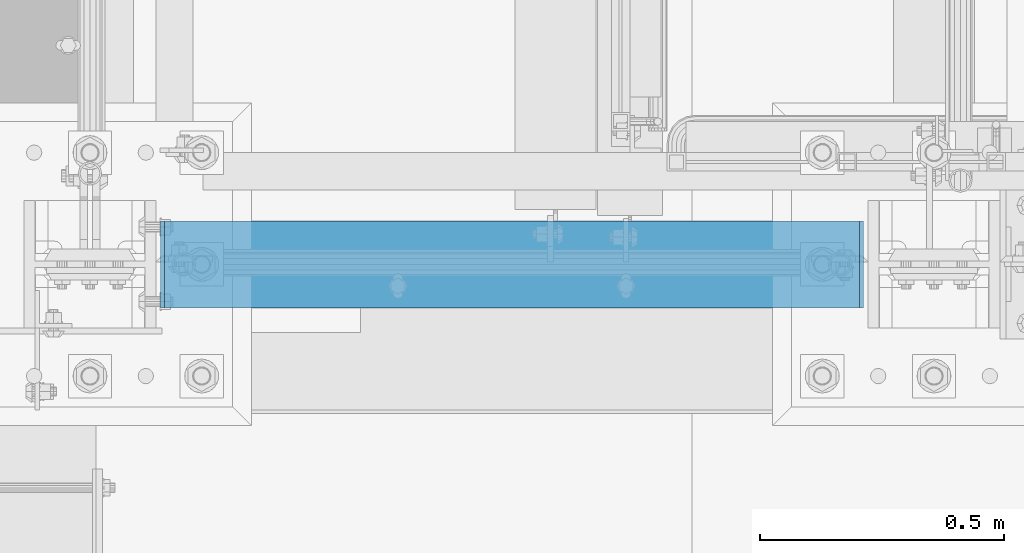
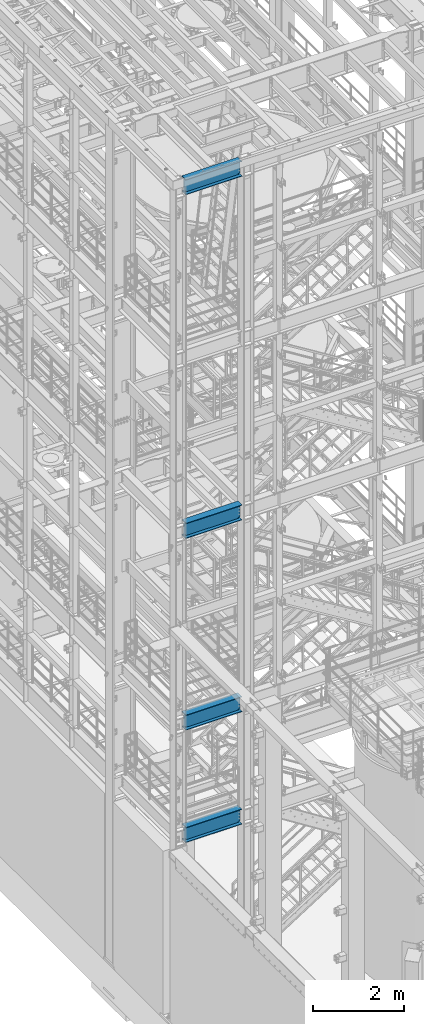
# One storey, part 932 of 1876: 4 beams, 4 elements without a shape of their own.
"""IFC2X3 building model written with IfcOpenShell, lengths in millimetres."""

import ifcopenshell
import ifcopenshell.guid

model = None  # the IFC model being written
_history = None  # IfcOwnerHistory: only IFC2X3 demands one
_inside = {}  # id of a spatial element -> (the spatial element, [elements in it])
_under = {}  # id of a project, library or spatial element -> (it, [spatial elements below it])
_declared = {}  # id of a project -> (the project, [libraries it declares])
_typed = {}  # id of a type object -> (the type object, [elements of that type])
_made_of = {}  # id of a material, layer set ... -> (it, [elements and type objects made of it])


def new_model(schema):
    """Start an empty IFC model of exactly this schema.

    Asked for "IFC4X3", IfcOpenShell would pick the latest addendum, in which some entities
    have other attributes; the version numbers below select the first issue.
    IFC2X3 requires an IfcOwnerHistory on every rooted entity: one is made here for all.
    """
    global model, _history
    if schema == "IFC4X3":
        model = ifcopenshell.file(schema_version=(4, 3, 0, 0))
    else:
        model = ifcopenshell.file(schema=schema)
    _inside.clear()
    _under.clear()
    _declared.clear()
    _typed.clear()
    _made_of.clear()
    _history = None
    if model.schema == "IFC2X3":
        org = make("IfcOrganization", Name="unknown")
        user = make(
            "IfcPersonAndOrganization",
            ThePerson=make("IfcPerson", FamilyName="unknown"),
            TheOrganization=org,
        )
        app = make(
            "IfcApplication",
            ApplicationDeveloper=org,
            Version="unknown",
            ApplicationFullName="unknown",
            ApplicationIdentifier="unknown",
        )
        _history = make(
            "IfcOwnerHistory",
            OwningUser=user,
            OwningApplication=app,
            ChangeAction="ADDED",
            CreationDate=0,
        )
    return model


def make(cls, **values):
    """One entity of the class cls with the attributes given. An attribute that is None is left unset."""
    return model.create_entity(
        cls, **{name: value for name, value in values.items() if value is not None}
    )


def rooted(cls, **values):
    """An entity with a GlobalId (a new one), such as an element, a storey or a relation."""
    return make(cls, GlobalId=ifcopenshell.guid.new(), OwnerHistory=_history, **values)


def si_unit(unit_type, name, prefix=None):
    """IfcSIUnit, for example si_unit("LENGTHUNIT", "METRE", prefix="MILLI")."""
    return make("IfcSIUnit", UnitType=unit_type, Prefix=prefix, Name=name)


def assignment(units):
    """IfcUnitAssignment: the units of a project."""
    return None if units is None else make("IfcUnitAssignment", Units=units)


def point(xyz):
    """IfcCartesianPoint."""
    return None if xyz is None else make("IfcCartesianPoint", Coordinates=xyz)


def direction(xyz):
    """IfcDirection."""
    return None if xyz is None else make("IfcDirection", DirectionRatios=xyz)


def frame(location, z_axis=None, x_axis=None):
    """IfcAxis2Placement3D, a coordinate frame: its origin and axes. An axis left out is left unset."""
    return make(
        "IfcAxis2Placement3D",
        Location=point(location),
        Axis=direction(z_axis),
        RefDirection=direction(x_axis),
    )


def origin_with_axes():
    """The frame at (0, 0, 0) with the z axis (0, 0, 1) and the x axis (1, 0, 0) written out."""
    return frame((0.0, 0.0, 0.0), z_axis=(0.0, 0.0, 1.0), x_axis=(1.0, 0.0, 0.0))


def place(relative_to, where):
    """IfcLocalPlacement: puts the frame where relative to a parent placement (None: the world)."""
    return make(
        "IfcLocalPlacement", PlacementRelTo=relative_to, RelativePlacement=where
    )


def context(
    kind, dimensions, precision=None, world=None, true_north=None, identifier=None
):
    """IfcGeometricRepresentationContext, for example the 3D "Model" context."""
    return make(
        "IfcGeometricRepresentationContext",
        ContextIdentifier=identifier,
        ContextType=kind,
        CoordinateSpaceDimension=dimensions,
        Precision=precision,
        WorldCoordinateSystem=world,
        TrueNorth=true_north,
    )


def subcontext(parent, identifier, kind, view, scale=None):
    """IfcGeometricRepresentationSubContext, for example "Body" below "Model"."""
    return make(
        "IfcGeometricRepresentationSubContext",
        ContextIdentifier=identifier,
        ContextType=kind,
        ParentContext=parent,
        TargetScale=scale,
        TargetView=view,
    )


def project(units=None, contexts=None):
    """IfcProject with its units and contexts."""
    return rooted(
        "IfcProject",
        Name="project",
        RepresentationContexts=contexts,
        UnitsInContext=assignment(units),
    )


def spatial(cls, under=None, at=None, **own):
    """A site, building, storey or space (cls), placed at a placement, below another one or the project."""
    s = rooted(cls, ObjectPlacement=at, **own)
    if under is not None:
        _under.setdefault(under.id(), (under, []))[1].append(s)
    return s


def faces_of(points, faces, orient=None, outer=None):
    """IfcFace entities. A face is a list of loops; a loop is a list of indices into points, from 0.

    orient and outer hold one flag for each loop. By default every Orientation is true, the
    first loop of a face is its IfcFaceOuterBound and the others are IfcFaceBound.
    """
    made = []
    for i, loops in enumerate(faces):
        bounds = []
        for j, loop in enumerate(loops):
            is_outer = j == 0 if outer is None else outer[i][j]
            bounds.append(
                make(
                    "IfcFaceOuterBound" if is_outer else "IfcFaceBound",
                    Bound=make("IfcPolyLoop", Polygon=[points[k] for k in loop]),
                    Orientation=True if orient is None else orient[i][j],
                )
            )
        made.append(make("IfcFace", Bounds=bounds))
    return made


def faceted_brep(points, faces, orient=None, outer=None, voids=None):
    """IfcFacetedBrep: a solid bounded by flat faces; with voids (closed shells), ...WithVoids."""
    shared = [point(p) for p in points]
    hull = make("IfcClosedShell", CfsFaces=faces_of(shared, faces, orient, outer))
    if voids is None:
        return make("IfcFacetedBrep", Outer=hull)
    return make(
        "IfcFacetedBrepWithVoids",
        Outer=hull,
        Voids=[
            make(cls, CfsFaces=faces_of(shared, fs, o, b)) for cls, fs, o, b in voids
        ],
    )


def shape(context_of_items, identifier, shape_type, items):
    """IfcShapeRepresentation: the items that make up one representation, for example the "Body"."""
    return make(
        "IfcShapeRepresentation",
        ContextOfItems=context_of_items,
        RepresentationIdentifier=identifier,
        RepresentationType=shape_type,
        Items=items,
    )


def material(Name=None, Category=None):
    """IfcMaterial."""
    return make("IfcMaterial", Name=Name, Category=Category)


def made_of(thing, what):
    """Note that an element or type object is made of a material, layer set ...; save() writes the relation."""
    if what is not None:
        _made_of.setdefault(what.id(), (what, []))[1].append(thing)
    return thing


def type_object(cls, material=None, **own):
    """A type object (cls), such as IfcWallType, which elements share."""
    return made_of(rooted(cls, **own), material)


def element(
    cls,
    number,
    at=None,
    inside=None,
    cuts=None,
    type_object=None,
    material=None,
    context=None,
    identifier="Body",
    shape_type=None,
    held_by="IfcProductDefinitionShape",
    body=None,
    shapes=None,
    **own,
):
    """One element of the class cls, such as IfcWall. Its Tag is "e" and its number.

    at: its placement. inside: the storey or other place that contains it. cuts: it is an
    opening in that element (IfcRelVoidsElement). A single representation is given by context,
    identifier, shape_type and body (its items); several are given by shapes. held_by: the class
    of the entity that holds the representations. save() writes the other relations.
    """
    e = rooted(cls, Tag="e%d" % number, ObjectPlacement=at, **own)
    if body is not None:
        shapes = [shape(context, identifier, shape_type, body)]
    if shapes is not None:
        e.Representation = make(held_by, Representations=shapes)
    if inside is not None:
        _inside.setdefault(inside.id(), (inside, []))[1].append(e)
    if cuts is not None:
        rooted(
            "IfcRelVoidsElement", RelatingBuildingElement=cuts, RelatedOpeningElement=e
        )
    if type_object is not None:
        _typed.setdefault(type_object.id(), (type_object, []))[1].append(e)
    return made_of(e, material)


def aggregate(whole, parts):
    """IfcRelAggregates: a whole, such as a stair, and the parts it consists of."""
    return rooted("IfcRelAggregates", RelatingObject=whole, RelatedObjects=parts)


def save(model, path):
    """Write the relations noted so far, then the file.

    IfcRelAggregates (storeys below a building ...), IfcRelContainedInSpatialStructure (elements
    in a storey), IfcRelDefinesByType, IfcRelAssociatesMaterial and IfcRelDeclares: one each for
    every whole, place, type object, material and project.
    """
    for whole, parts in _under.values():
        aggregate(whole, parts)
    for where, things in _inside.values():
        rooted(
            "IfcRelContainedInSpatialStructure",
            RelatedElements=things,
            RelatingStructure=where,
        )
    for kind, things in _typed.values():
        rooted("IfcRelDefinesByType", RelatedObjects=things, RelatingType=kind)
    for what, things in _made_of.values():
        rooted("IfcRelAssociatesMaterial", RelatedObjects=things, RelatingMaterial=what)
    for by, libraries in _declared.values():
        rooted("IfcRelDeclares", RelatingContext=by, RelatedDefinitions=libraries)
    model.write(path)


model = new_model("IFC2X3")

# Units and contexts
model_context = context("Model", 3, precision=1e-05, world=origin_with_axes())
body_context = subcontext(model_context, "Body", "Model", "MODEL_VIEW")
ifc_project = project(units=[si_unit("LENGTHUNIT", "METRE", prefix="MILLI"), si_unit("AREAUNIT", "SQUARE_METRE"), si_unit("VOLUMEUNIT", "CUBIC_METRE"), si_unit("MASSUNIT", "GRAM", prefix="KILO"), si_unit("TIMEUNIT", "SECOND"), si_unit("PLANEANGLEUNIT", "RADIAN"), si_unit("SOLIDANGLEUNIT", "STERADIAN"), si_unit("THERMODYNAMICTEMPERATUREUNIT", "DEGREE_CELSIUS"), si_unit("LUMINOUSINTENSITYUNIT", "LUMEN")], contexts=[model_context])

# Site, building, storey
site_placement = place(None, origin_with_axes())
site = spatial("IfcSite", under=ifc_project, at=site_placement, CompositionType="ELEMENT")
building_placement = place(site_placement, origin_with_axes())
building = spatial("IfcBuilding", under=site, at=building_placement, Name="Undefined", CompositionType="ELEMENT")
storey_placement = place(building_placement, origin_with_axes())
storey = spatial("IfcBuildingStorey", under=building, at=storey_placement, Name="Undefined", CompositionType="ELEMENT", Elevation=0.0)

# Assembly, beam
assembly_1_placement = place(storey_placement, origin_with_axes())
assembly_1 = element("IfcElementAssembly", 1, at=assembly_1_placement, inside=storey, Name="BEAM", AssemblyPlace="NOTDEFINED", PredefinedType="RIGID_FRAME")
ifc_material = material(Name="STEEL/A992")
beam_type = type_object("IfcBeamType", Name="W16X45", PredefinedType="NOTDEFINED")
beam_1_placement = place(assembly_1_placement, frame((0.0, -7112.0, 13104.8125), z_axis=(0.0, 0.0, 1.0), x_axis=(1.0, 0.0, 0.0)))
beam_1 = element("IfcBeam", 2, at=beam_1_placement, type_object=beam_type, material=ifc_material, Name="BEAM", ObjectType="W16X45", context=body_context, shape_type="Brep", body=[
    faceted_brep([(1582.7375, 4.76249999999982, 161.924999999999), (1573.21249970572, -4.76249999999982, 161.924999999999), (1573.21249970572, -4.76249999999982, -161.924999999999), (1582.7375, 4.76249999999982, -161.924999999999), (144.4625, 88.8999999999996, 190.5), (152.711099599373, 88.8999999999996, 204.787499999999), (1574.48890040062, 88.8999999999996, 204.787499999999), (1582.7375, 88.8999999999996, 190.5), (144.4625, 4.76249999999982, 190.5), (1582.7375, 4.76249999999982, 190.5), (152.711120260645, -88.8999999999996, -190.5), (144.4625, -88.8999999999996, -204.787499999999), (1582.7375, -88.8999999999996, -204.787499999999), (1574.48887973935, -88.8999999999996, -190.5), (144.4625, 88.8999999999996, -204.787499999999), (1582.7375, 88.8999999999996, -204.787499999999), (152.711120260645, 88.8999999999996, -190.5), (1574.48887973935, 88.8999999999996, -190.5), (152.711120260645, 4.76249999999982, -190.5), (1574.48887973935, 4.76249999999982, -190.5), (1530.71330732956, -4.76249999999982, -163.290718362852), (1530.71330732956, 4.76249999999982, -163.290718362852), (1535.62775003691, 4.76249999999982, -161.924999999999), (1535.62775003691, -4.76249999999982, -161.924999999999), (1527.20815489359, -4.76249999999982, -166.996233194965), (1527.20815489359, 4.76249999999982, -166.996233194965), (1526.11744784461, -4.76249999999982, -171.978932453771), (1526.11744784461, 4.76249999999982, -171.978932453771), (1527.75396281358, -4.76249999999982, -176.80995227641), (1527.75396281358, 4.76249999999982, -176.80995227641), (1531.64840454932, -4.76249999999982, -180.103925156887), (1531.64840454932, 4.76249999999982, -180.103925156887), (1553.39349932861, -4.76249999999982, -190.102999496459), (1553.39349932861, 4.76249999999982, -190.102999496459), (1574.25968949887, -4.76249999999982, -190.102999496459), (1574.25968949887, 4.76249999999982, -190.102999496459), (1574.48887973935, -4.76249999999982, -190.5), (152.711120260645, -4.76249999999982, -190.5), (152.940310501126, -4.76249999999982, -190.102999496459), (152.940310501126, 4.76249999999982, -190.102999496459), (173.806500671387, -4.76249999999982, -190.102999496459), (173.806500671387, 4.76249999999982, -190.102999496459), (195.551595450686, -4.76249999999982, -180.103925156884), (195.551595450686, 4.76249999999982, -180.103925156884), (199.446037186428, -4.76249999999982, -176.80995227641), (199.446037186428, 4.76249999999982, -176.80995227641), (201.082552155395, -4.76249999999982, -171.978932453767), (201.082552155395, 4.76249999999982, -171.978932453767), (199.991845106413, -4.76249999999982, -166.996233194965), (199.991845106413, 4.76249999999982, -166.996233194965), (196.486692670442, -4.76249999999982, -163.290718362852), (196.486692670442, 4.76249999999982, -163.290718362852), (191.572249963099, -4.76249999999982, -161.924999999999), (191.572249963099, 4.76249999999982, -161.924999999999), (153.987500294277, -4.76249999999982, -161.924999999996), (144.4625, 4.76249999999982, -161.924999999996), (153.987500294277, -4.7625002942832, 161.925000000003), (144.4625, 4.76249999999982, 161.925000000003), (190.80324988243, -4.76249999999982, 161.924999999999), (190.80324988243, 4.76249999999982, 161.924999999999), (195.717692628333, -4.76249999999982, 163.290718386077), (195.717692628333, 4.76249999999982, 163.290718386077), (199.22284506784, -4.76249999999982, 166.996233274545), (199.22284506784, 4.76249999999982, 166.996233274545), (200.313552067229, -4.76249999999982, 171.978932588601), (200.313552067229, 4.76249999999982, 171.978932588601), (198.677037004441, -4.76249999999982, 176.80995242525), (198.677037004441, 4.76249999999982, 176.80995242525), (194.782595165536, -4.76249999999982, 180.103925250914), (194.782595165536, 4.76249999999982, 180.103925250914), (173.037499237061, -4.76249999999982, 190.102999496463), (173.037499237061, 4.76249999999982, 190.102999496463), (144.4625, -4.76249999999982, 190.102999496463), (144.4625, 4.76249999999982, 190.102999496463), (144.4625, -4.76249999999982, 190.5), (152.711099599373, -88.8999999999996, 204.787499999999), (144.4625, -88.8999999999996, 190.5), (1582.7375, -4.76249999999982, 190.5), (1582.7375, -88.8999999999996, 190.5), (1574.48890040062, -88.8999999999996, 204.787499999999), (1582.7375, -4.76249999999982, 190.102999496459), (1582.7375, 4.76249999999982, 190.102999496459), (1554.16250076294, -4.76249999999982, 190.102999496459), (1554.16250076294, 4.76249999999982, 190.102999496459), (1532.41740483447, -4.76249999999982, 180.103925250914), (1532.41740483447, 4.76249999999982, 180.103925250914), (1528.52296299556, -4.76249999999982, 176.80995242525), (1528.52296299556, 4.76249999999982, 176.80995242525), (1526.88644793277, -4.76249999999982, 171.978932588601), (1526.88644793277, 4.76249999999982, 171.978932588601), (1527.97715493216, -4.76249999999982, 166.996233274542), (1527.97715493216, 4.76249999999982, 166.996233274542), (1531.48230737167, -4.76249999999982, 163.290718386077), (1531.48230737167, 4.76249999999982, 163.290718386077), (1536.39675011757, -4.76249999999982, 161.924999999999), (1536.39675011757, 4.76249999999982, 161.924999999999)], [[[0, 1, 2, 3]], [[4, 5, 6, 7]], [[8, 4, 7, 9]], [[10, 11, 12, 13]], [[11, 14, 15, 12]], [[14, 16, 17, 15]], [[16, 18, 19, 17]], [[20, 21, 22, 23]], [[24, 25, 21, 20]], [[26, 27, 25, 24]], [[28, 29, 27, 26]], [[30, 31, 29, 28]], [[32, 33, 31, 30]], [[33, 32, 34, 35]], [[12, 15, 17, 19, 35, 34, 36, 13]], [[37, 10, 13, 36]], [[38, 39, 18, 16, 14, 11, 10, 37]], [[40, 41, 39, 38]], [[42, 43, 41, 40]], [[44, 45, 43, 42]], [[46, 47, 45, 44]], [[48, 49, 47, 46]], [[50, 51, 49, 48]], [[52, 53, 51, 50]], [[53, 52, 54, 55]], [[56, 57, 55, 54]], [[58, 59, 57, 56]], [[60, 61, 59, 58]], [[62, 63, 61, 60]], [[64, 65, 63, 62]], [[66, 67, 65, 64]], [[68, 69, 67, 66]], [[70, 71, 69, 68]], [[71, 70, 72, 73]], [[73, 72, 74, 8]], [[75, 5, 4, 8, 74, 76]], [[76, 74, 77, 78]], [[75, 76, 78, 79]], [[5, 75, 79, 6]], [[78, 77, 9, 7, 6, 79]], [[80, 81, 9, 77]], [[82, 83, 81, 80]], [[84, 85, 83, 82]], [[86, 87, 85, 84]], [[88, 89, 87, 86]], [[90, 91, 89, 88]], [[92, 93, 91, 90]], [[94, 95, 93, 92]], [[22, 21, 25, 27, 29, 31, 33, 35, 19, 18, 39, 41, 43, 45, 47, 49, 51, 53, 55, 57, 59, 61, 63, 65, 67, 69, 71, 73, 8, 9, 81, 83, 85, 87, 89, 91, 93, 95, 0, 3]], [[23, 22, 3, 2]], [[94, 92, 90, 88, 86, 84, 82, 80, 77, 74, 72, 70, 68, 66, 64, 62, 60, 58, 56, 54, 52, 50, 48, 46, 44, 42, 40, 38, 37, 36, 34, 32, 30, 28, 26, 24, 20, 23, 2, 1]], [[95, 94, 1, 0]]]),
])
aggregate(assembly_1, [beam_1])

assembly_2_placement = place(storey_placement, origin_with_axes())
assembly_2 = element("IfcElementAssembly", 3, at=assembly_2_placement, inside=storey, Name="BEAM", AssemblyPlace="NOTDEFINED", PredefinedType="RIGID_FRAME")
beam_2_placement = place(assembly_2_placement, frame((0.0, -7112.0, 7948.6125), z_axis=(0.0, 0.0, 1.0), x_axis=(1.0, 0.0, 0.0)))
beam_2 = element("IfcBeam", 4, at=beam_2_placement, type_object=beam_type, material=ifc_material, Name="BEAM", ObjectType="W16X45", context=body_context, shape_type="Brep", body=[
    faceted_brep([(1582.7375, 4.76249999999982, 161.924999999999), (1573.21249970572, -4.76249999999982, 161.924999999999), (1573.21249970572, -4.76249999999982, -161.924999999999), (1582.7375, 4.76249999999982, -161.924999999999), (144.4625, 88.8999999999996, 190.5), (152.711099599373, 88.8999999999996, 204.787499999999), (1574.48890040062, 88.8999999999996, 204.787499999999), (1582.7375, 88.8999999999996, 190.5), (144.4625, 4.76249999999982, 190.5), (1582.7375, 4.76249999999982, 190.5), (152.711120260645, -88.8999999999996, -190.5), (144.4625, -88.8999999999996, -204.787499999999), (1582.7375, -88.8999999999996, -204.787499999999), (1574.48887973935, -88.8999999999996, -190.5), (144.4625, 88.8999999999996, -204.787499999999), (1582.7375, 88.8999999999996, -204.787499999999), (152.711120260645, 88.8999999999996, -190.5), (1574.48887973935, 88.8999999999996, -190.5), (152.711120260645, 4.76249999999982, -190.5), (1574.48887973935, 4.76249999999982, -190.5), (1530.71330732956, -4.76249999999982, -163.290718362852), (1530.71330732956, 4.76249999999982, -163.290718362852), (1535.62775003691, 4.76249999999982, -161.924999999999), (1535.62775003691, -4.76249999999982, -161.924999999999), (1527.20815489359, -4.76249999999982, -166.996233194965), (1527.20815489359, 4.76249999999982, -166.996233194965), (1526.11744784461, -4.76249999999982, -171.978932453771), (1526.11744784461, 4.76249999999982, -171.978932453771), (1527.75396281358, -4.76249999999982, -176.80995227641), (1527.75396281358, 4.76249999999982, -176.80995227641), (1531.64840454932, -4.76249999999982, -180.103925156887), (1531.64840454932, 4.76249999999982, -180.103925156887), (1553.39349932861, -4.76249999999982, -190.102999496459), (1553.39349932861, 4.76249999999982, -190.102999496459), (1574.25968949887, -4.76249999999982, -190.102999496459), (1574.25968949887, 4.76249999999982, -190.102999496459), (1574.48887973935, -4.76249999999982, -190.5), (152.711120260645, -4.76249999999982, -190.5), (152.940310501126, -4.76249999999982, -190.102999496459), (152.940310501126, 4.76249999999982, -190.102999496459), (173.806500671387, -4.76249999999982, -190.102999496459), (173.806500671387, 4.76249999999982, -190.102999496459), (195.551595450686, -4.76249999999982, -180.103925156884), (195.551595450686, 4.76249999999982, -180.103925156884), (199.446037186428, -4.76249999999982, -176.80995227641), (199.446037186428, 4.76249999999982, -176.80995227641), (201.082552155395, -4.76249999999982, -171.978932453767), (201.082552155395, 4.76249999999982, -171.978932453767), (199.991845106413, -4.76249999999982, -166.996233194965), (199.991845106413, 4.76249999999982, -166.996233194965), (196.486692670442, -4.76249999999982, -163.290718362852), (196.486692670442, 4.76249999999982, -163.290718362852), (191.572249963099, -4.76249999999982, -161.924999999999), (191.572249963099, 4.76249999999982, -161.924999999999), (153.987500294277, -4.76249999999982, -161.924999999996), (144.4625, 4.76249999999982, -161.924999999996), (153.987500294277, -4.7625002942832, 161.925000000003), (144.4625, 4.76249999999982, 161.925000000003), (190.80324988243, -4.76249999999982, 161.924999999999), (190.80324988243, 4.76249999999982, 161.924999999999), (195.717692628333, -4.76249999999982, 163.290718386077), (195.717692628333, 4.76249999999982, 163.290718386077), (199.22284506784, -4.76249999999982, 166.996233274545), (199.22284506784, 4.76249999999982, 166.996233274545), (200.313552067229, -4.76249999999982, 171.978932588601), (200.313552067229, 4.76249999999982, 171.978932588601), (198.677037004441, -4.76249999999982, 176.80995242525), (198.677037004441, 4.76249999999982, 176.80995242525), (194.782595165536, -4.76249999999982, 180.103925250914), (194.782595165536, 4.76249999999982, 180.103925250914), (173.037499237061, -4.76249999999982, 190.102999496463), (173.037499237061, 4.76249999999982, 190.102999496463), (144.4625, -4.76249999999982, 190.102999496463), (144.4625, 4.76249999999982, 190.102999496463), (144.4625, -4.76249999999982, 190.5), (152.711099599373, -88.8999999999996, 204.787499999999), (144.4625, -88.8999999999996, 190.5), (1582.7375, -4.76249999999982, 190.5), (1582.7375, -88.8999999999996, 190.5), (1574.48890040062, -88.8999999999996, 204.787499999999), (1582.7375, -4.76249999999982, 190.102999496459), (1582.7375, 4.76249999999982, 190.102999496459), (1554.16250076294, -4.76249999999982, 190.102999496459), (1554.16250076294, 4.76249999999982, 190.102999496459), (1532.41740483447, -4.76249999999982, 180.103925250914), (1532.41740483447, 4.76249999999982, 180.103925250914), (1528.52296299556, -4.76249999999982, 176.80995242525), (1528.52296299556, 4.76249999999982, 176.80995242525), (1526.88644793277, -4.76249999999982, 171.978932588601), (1526.88644793277, 4.76249999999982, 171.978932588601), (1527.97715493216, -4.76249999999982, 166.996233274542), (1527.97715493216, 4.76249999999982, 166.996233274542), (1531.48230737167, -4.76249999999982, 163.290718386077), (1531.48230737167, 4.76249999999982, 163.290718386077), (1536.39675011757, -4.76249999999982, 161.924999999999), (1536.39675011757, 4.76249999999982, 161.924999999999)], [[[0, 1, 2, 3]], [[4, 5, 6, 7]], [[8, 4, 7, 9]], [[10, 11, 12, 13]], [[11, 14, 15, 12]], [[14, 16, 17, 15]], [[16, 18, 19, 17]], [[20, 21, 22, 23]], [[24, 25, 21, 20]], [[26, 27, 25, 24]], [[28, 29, 27, 26]], [[30, 31, 29, 28]], [[32, 33, 31, 30]], [[33, 32, 34, 35]], [[12, 15, 17, 19, 35, 34, 36, 13]], [[37, 10, 13, 36]], [[38, 39, 18, 16, 14, 11, 10, 37]], [[40, 41, 39, 38]], [[42, 43, 41, 40]], [[44, 45, 43, 42]], [[46, 47, 45, 44]], [[48, 49, 47, 46]], [[50, 51, 49, 48]], [[52, 53, 51, 50]], [[53, 52, 54, 55]], [[56, 57, 55, 54]], [[58, 59, 57, 56]], [[60, 61, 59, 58]], [[62, 63, 61, 60]], [[64, 65, 63, 62]], [[66, 67, 65, 64]], [[68, 69, 67, 66]], [[70, 71, 69, 68]], [[71, 70, 72, 73]], [[73, 72, 74, 8]], [[75, 5, 4, 8, 74, 76]], [[76, 74, 77, 78]], [[75, 76, 78, 79]], [[5, 75, 79, 6]], [[78, 77, 9, 7, 6, 79]], [[80, 81, 9, 77]], [[82, 83, 81, 80]], [[84, 85, 83, 82]], [[86, 87, 85, 84]], [[88, 89, 87, 86]], [[90, 91, 89, 88]], [[92, 93, 91, 90]], [[94, 95, 93, 92]], [[22, 21, 25, 27, 29, 31, 33, 35, 19, 18, 39, 41, 43, 45, 47, 49, 51, 53, 55, 57, 59, 61, 63, 65, 67, 69, 71, 73, 8, 9, 81, 83, 85, 87, 89, 91, 93, 95, 0, 3]], [[23, 22, 3, 2]], [[94, 92, 90, 88, 86, 84, 82, 80, 77, 74, 72, 70, 68, 66, 64, 62, 60, 58, 56, 54, 52, 50, 48, 46, 44, 42, 40, 38, 37, 36, 34, 32, 30, 28, 26, 24, 20, 23, 2, 1]], [[95, 94, 1, 0]]]),
])
aggregate(assembly_2, [beam_2])

assembly_3_placement = place(storey_placement, origin_with_axes())
assembly_3 = element("IfcElementAssembly", 5, at=assembly_3_placement, inside=storey, Name="BEAM", AssemblyPlace="NOTDEFINED", PredefinedType="RIGID_FRAME")
beam_3_placement = place(assembly_3_placement, frame((0.0, -7112.0, 22350.4125), z_axis=(0.0, 0.0, 1.0), x_axis=(1.0, 0.0, 0.0)))
beam_3 = element("IfcBeam", 6, at=beam_3_placement, type_object=beam_type, material=ifc_material, Name="BEAM", ObjectType="W16X45", context=body_context, shape_type="Brep", body=[
    faceted_brep([(1582.7375, 4.76249999999982, 161.924999999999), (1573.21249970572, -4.76249999999982, 161.924999999999), (1573.21249970572, -4.76249999999982, -161.924999999999), (1582.7375, 4.76249999999982, -161.924999999999), (144.4625, 88.8999999999996, 190.5), (152.711099599373, 88.8999999999996, 204.787499999999), (1574.48890040062, 88.8999999999996, 204.787499999999), (1582.7375, 88.8999999999996, 190.5), (144.4625, 4.76249999999982, 190.5), (1582.7375, 4.76249999999982, 190.5), (152.711120260645, -88.8999999999996, -190.5), (144.4625, -88.8999999999996, -204.787499999999), (1582.7375, -88.8999999999996, -204.787499999999), (1574.48887973935, -88.8999999999996, -190.5), (144.4625, 88.8999999999996, -204.787499999999), (1582.7375, 88.8999999999996, -204.787499999999), (152.711120260645, 88.8999999999996, -190.5), (1574.48887973935, 88.8999999999996, -190.5), (152.711120260645, 4.76249999999982, -190.5), (1574.48887973935, 4.76249999999982, -190.5), (1530.71330732956, -4.76249999999982, -163.290718362852), (1530.71330732956, 4.76249999999982, -163.290718362852), (1535.62775003691, 4.76249999999982, -161.924999999999), (1535.62775003691, -4.76249999999982, -161.924999999999), (1527.20815489359, -4.76249999999982, -166.996233194965), (1527.20815489359, 4.76249999999982, -166.996233194965), (1526.11744784461, -4.76249999999982, -171.978932453771), (1526.11744784461, 4.76249999999982, -171.978932453771), (1527.75396281358, -4.76249999999982, -176.80995227641), (1527.75396281358, 4.76249999999982, -176.80995227641), (1531.64840454932, -4.76249999999982, -180.103925156887), (1531.64840454932, 4.76249999999982, -180.103925156887), (1553.39349932861, -4.76249999999982, -190.102999496459), (1553.39349932861, 4.76249999999982, -190.102999496459), (1574.25968949887, -4.76249999999982, -190.102999496459), (1574.25968949887, 4.76249999999982, -190.102999496459), (1574.48887973935, -4.76249999999982, -190.5), (152.711120260645, -4.76249999999982, -190.5), (152.940310501126, -4.76249999999982, -190.102999496459), (152.940310501126, 4.76249999999982, -190.102999496459), (173.806500671387, -4.76249999999982, -190.102999496459), (173.806500671387, 4.76249999999982, -190.102999496459), (195.551595450686, -4.76249999999982, -180.103925156884), (195.551595450686, 4.76249999999982, -180.103925156884), (199.446037186428, -4.76249999999982, -176.80995227641), (199.446037186428, 4.76249999999982, -176.80995227641), (201.082552155395, -4.76249999999982, -171.978932453767), (201.082552155395, 4.76249999999982, -171.978932453767), (199.991845106413, -4.76249999999982, -166.996233194965), (199.991845106413, 4.76249999999982, -166.996233194965), (196.486692670442, -4.76249999999982, -163.290718362852), (196.486692670442, 4.76249999999982, -163.290718362852), (191.572249963099, -4.76249999999982, -161.924999999999), (191.572249963099, 4.76249999999982, -161.924999999999), (153.987500294277, -4.76249999999982, -161.924999999996), (144.4625, 4.76249999999982, -161.924999999996), (153.987500294277, -4.7625002942832, 161.925000000003), (144.4625, 4.76249999999982, 161.925000000003), (190.80324988243, -4.76249999999982, 161.924999999999), (190.80324988243, 4.76249999999982, 161.924999999999), (195.717692628333, -4.76249999999982, 163.290718386077), (195.717692628333, 4.76249999999982, 163.290718386077), (199.22284506784, -4.76249999999982, 166.996233274545), (199.22284506784, 4.76249999999982, 166.996233274545), (200.313552067229, -4.76249999999982, 171.978932588601), (200.313552067229, 4.76249999999982, 171.978932588601), (198.677037004441, -4.76249999999982, 176.80995242525), (198.677037004441, 4.76249999999982, 176.80995242525), (194.782595165536, -4.76249999999982, 180.103925250914), (194.782595165536, 4.76249999999982, 180.103925250914), (173.037499237061, -4.76249999999982, 190.102999496463), (173.037499237061, 4.76249999999982, 190.102999496463), (144.4625, -4.76249999999982, 190.102999496463), (144.4625, 4.76249999999982, 190.102999496463), (144.4625, -4.76249999999982, 190.5), (152.711099599373, -88.8999999999996, 204.787499999999), (144.4625, -88.8999999999996, 190.5), (1582.7375, -4.76249999999982, 190.5), (1582.7375, -88.8999999999996, 190.5), (1574.48890040062, -88.8999999999996, 204.787499999999), (1582.7375, -4.76249999999982, 190.102999496459), (1582.7375, 4.76249999999982, 190.102999496459), (1554.16250076294, -4.76249999999982, 190.102999496459), (1554.16250076294, 4.76249999999982, 190.102999496459), (1532.41740483447, -4.76249999999982, 180.103925250914), (1532.41740483447, 4.76249999999982, 180.103925250914), (1528.52296299556, -4.76249999999982, 176.80995242525), (1528.52296299556, 4.76249999999982, 176.80995242525), (1526.88644793277, -4.76249999999982, 171.978932588601), (1526.88644793277, 4.76249999999982, 171.978932588601), (1527.97715493216, -4.76249999999982, 166.996233274542), (1527.97715493216, 4.76249999999982, 166.996233274542), (1531.48230737167, -4.76249999999982, 163.290718386077), (1531.48230737167, 4.76249999999982, 163.290718386077), (1536.39675011757, -4.76249999999982, 161.924999999999), (1536.39675011757, 4.76249999999982, 161.924999999999)], [[[0, 1, 2, 3]], [[4, 5, 6, 7]], [[8, 4, 7, 9]], [[10, 11, 12, 13]], [[11, 14, 15, 12]], [[14, 16, 17, 15]], [[16, 18, 19, 17]], [[20, 21, 22, 23]], [[24, 25, 21, 20]], [[26, 27, 25, 24]], [[28, 29, 27, 26]], [[30, 31, 29, 28]], [[32, 33, 31, 30]], [[33, 32, 34, 35]], [[12, 15, 17, 19, 35, 34, 36, 13]], [[37, 10, 13, 36]], [[38, 39, 18, 16, 14, 11, 10, 37]], [[40, 41, 39, 38]], [[42, 43, 41, 40]], [[44, 45, 43, 42]], [[46, 47, 45, 44]], [[48, 49, 47, 46]], [[50, 51, 49, 48]], [[52, 53, 51, 50]], [[53, 52, 54, 55]], [[56, 57, 55, 54]], [[58, 59, 57, 56]], [[60, 61, 59, 58]], [[62, 63, 61, 60]], [[64, 65, 63, 62]], [[66, 67, 65, 64]], [[68, 69, 67, 66]], [[70, 71, 69, 68]], [[71, 70, 72, 73]], [[73, 72, 74, 8]], [[75, 5, 4, 8, 74, 76]], [[76, 74, 77, 78]], [[75, 76, 78, 79]], [[5, 75, 79, 6]], [[78, 77, 9, 7, 6, 79]], [[80, 81, 9, 77]], [[82, 83, 81, 80]], [[84, 85, 83, 82]], [[86, 87, 85, 84]], [[88, 89, 87, 86]], [[90, 91, 89, 88]], [[92, 93, 91, 90]], [[94, 95, 93, 92]], [[22, 21, 25, 27, 29, 31, 33, 35, 19, 18, 39, 41, 43, 45, 47, 49, 51, 53, 55, 57, 59, 61, 63, 65, 67, 69, 71, 73, 8, 9, 81, 83, 85, 87, 89, 91, 93, 95, 0, 3]], [[23, 22, 3, 2]], [[94, 92, 90, 88, 86, 84, 82, 80, 77, 74, 72, 70, 68, 66, 64, 62, 60, 58, 56, 54, 52, 50, 48, 46, 44, 42, 40, 38, 37, 36, 34, 32, 30, 28, 26, 24, 20, 23, 2, 1]], [[95, 94, 1, 0]]]),
])
aggregate(assembly_3, [beam_3])

assembly_4_placement = place(storey_placement, origin_with_axes())
assembly_4 = element("IfcElementAssembly", 7, at=assembly_4_placement, inside=storey, Name="BEAM", AssemblyPlace="NOTDEFINED", PredefinedType="RIGID_FRAME")
beam_4_placement = place(assembly_4_placement, frame((0.0, -7112.0, 4926.0125), z_axis=(0.0, 0.0, 1.0), x_axis=(1.0, 0.0, 0.0)))
beam_4 = element("IfcBeam", 8, at=beam_4_placement, type_object=beam_type, material=ifc_material, Name="BEAM", ObjectType="W16X45", context=body_context, shape_type="Brep", body=[
    faceted_brep([(1582.7375, 4.76249999999982, 161.924999999999), (1573.21249970572, -4.76249999999982, 161.924999999999), (1573.21249970572, -4.76249999999982, -161.924999999999), (1582.7375, 4.76249999999982, -161.924999999999), (144.4625, 88.8999999999996, 190.5), (152.711099599373, 88.8999999999996, 204.787499999999), (1574.48890040062, 88.8999999999996, 204.787499999999), (1582.7375, 88.8999999999996, 190.5), (144.4625, 4.76249999999982, 190.5), (1582.7375, 4.76249999999982, 190.5), (152.711120260645, -88.8999999999996, -190.5), (144.4625, -88.8999999999996, -204.787499999999), (1582.7375, -88.8999999999996, -204.787499999999), (1574.48887973935, -88.8999999999996, -190.5), (144.4625, 88.8999999999996, -204.787499999999), (1582.7375, 88.8999999999996, -204.787499999999), (152.711120260645, 88.8999999999996, -190.5), (1574.48887973935, 88.8999999999996, -190.5), (152.711120260645, 4.76249999999982, -190.5), (1574.48887973935, 4.76249999999982, -190.5), (1530.71330732956, -4.76249999999982, -163.290718362852), (1530.71330732956, 4.76249999999982, -163.290718362852), (1535.62775003691, 4.76249999999982, -161.924999999999), (1535.62775003691, -4.76249999999982, -161.924999999999), (1527.20815489359, -4.76249999999982, -166.996233194965), (1527.20815489359, 4.76249999999982, -166.996233194965), (1526.11744784461, -4.76249999999982, -171.978932453771), (1526.11744784461, 4.76249999999982, -171.978932453771), (1527.75396281358, -4.76249999999982, -176.80995227641), (1527.75396281358, 4.76249999999982, -176.80995227641), (1531.64840454932, -4.76249999999982, -180.103925156887), (1531.64840454932, 4.76249999999982, -180.103925156887), (1553.39349932861, -4.76249999999982, -190.102999496459), (1553.39349932861, 4.76249999999982, -190.102999496459), (1574.25968949887, -4.76249999999982, -190.102999496459), (1574.25968949887, 4.76249999999982, -190.102999496459), (1574.48887973935, -4.76249999999982, -190.5), (152.711120260645, -4.76249999999982, -190.5), (152.940310501126, -4.76249999999982, -190.102999496459), (152.940310501126, 4.76249999999982, -190.102999496459), (173.806500671387, -4.76249999999982, -190.102999496459), (173.806500671387, 4.76249999999982, -190.102999496459), (195.551595450686, -4.76249999999982, -180.103925156884), (195.551595450686, 4.76249999999982, -180.103925156884), (199.446037186428, -4.76249999999982, -176.80995227641), (199.446037186428, 4.76249999999982, -176.80995227641), (201.082552155395, -4.76249999999982, -171.978932453767), (201.082552155395, 4.76249999999982, -171.978932453767), (199.991845106413, -4.76249999999982, -166.996233194965), (199.991845106413, 4.76249999999982, -166.996233194965), (196.486692670442, -4.76249999999982, -163.290718362852), (196.486692670442, 4.76249999999982, -163.290718362852), (191.572249963099, -4.76249999999982, -161.924999999999), (191.572249963099, 4.76249999999982, -161.924999999999), (153.987500294277, -4.76249999999982, -161.924999999996), (144.4625, 4.76249999999982, -161.924999999996), (153.987500294277, -4.7625002942832, 161.925000000003), (144.4625, 4.76249999999982, 161.925000000003), (190.80324988243, -4.76249999999982, 161.924999999999), (190.80324988243, 4.76249999999982, 161.924999999999), (195.717692628333, -4.76249999999982, 163.290718386077), (195.717692628333, 4.76249999999982, 163.290718386077), (199.22284506784, -4.76249999999982, 166.996233274545), (199.22284506784, 4.76249999999982, 166.996233274545), (200.313552067229, -4.76249999999982, 171.978932588601), (200.313552067229, 4.76249999999982, 171.978932588601), (198.677037004441, -4.76249999999982, 176.80995242525), (198.677037004441, 4.76249999999982, 176.80995242525), (194.782595165536, -4.76249999999982, 180.103925250914), (194.782595165536, 4.76249999999982, 180.103925250914), (173.037499237061, -4.76249999999982, 190.102999496463), (173.037499237061, 4.76249999999982, 190.102999496463), (144.4625, -4.76249999999982, 190.102999496463), (144.4625, 4.76249999999982, 190.102999496463), (144.4625, -4.76249999999982, 190.5), (152.711099599373, -88.8999999999996, 204.787499999999), (144.4625, -88.8999999999996, 190.5), (1582.7375, -88.8999999999996, 190.5), (1574.48890040062, -88.8999999999996, 204.787499999999), (1582.7375, -4.76249999999982, 190.5), (1582.7375, -4.76249999999982, 190.102999496459), (1582.7375, 4.76249999999982, 190.102999496459), (1554.16250076294, -4.76249999999982, 190.102999496459), (1554.16250076294, 4.76249999999982, 190.102999496459), (1532.41740483447, -4.76249999999982, 180.103925250914), (1532.41740483447, 4.76249999999982, 180.103925250914), (1528.52296299556, -4.76249999999982, 176.80995242525), (1528.52296299556, 4.76249999999982, 176.80995242525), (1526.88644793277, -4.76249999999982, 171.978932588601), (1526.88644793277, 4.76249999999982, 171.978932588601), (1527.97715493216, -4.76249999999982, 166.996233274542), (1527.97715493216, 4.76249999999982, 166.996233274542), (1531.48230737167, -4.76249999999982, 163.290718386077), (1531.48230737167, 4.76249999999982, 163.290718386077), (1536.39675011757, -4.76249999999982, 161.924999999999), (1536.39675011757, 4.76249999999982, 161.924999999999)], [[[0, 1, 2, 3]], [[4, 5, 6, 7]], [[8, 4, 7, 9]], [[10, 11, 12, 13]], [[11, 14, 15, 12]], [[14, 16, 17, 15]], [[16, 18, 19, 17]], [[20, 21, 22, 23]], [[24, 25, 21, 20]], [[26, 27, 25, 24]], [[28, 29, 27, 26]], [[30, 31, 29, 28]], [[32, 33, 31, 30]], [[33, 32, 34, 35]], [[12, 15, 17, 19, 35, 34, 36, 13]], [[37, 10, 13, 36]], [[38, 39, 18, 16, 14, 11, 10, 37]], [[40, 41, 39, 38]], [[42, 43, 41, 40]], [[44, 45, 43, 42]], [[46, 47, 45, 44]], [[48, 49, 47, 46]], [[50, 51, 49, 48]], [[52, 53, 51, 50]], [[53, 52, 54, 55]], [[56, 57, 55, 54]], [[58, 59, 57, 56]], [[60, 61, 59, 58]], [[62, 63, 61, 60]], [[64, 65, 63, 62]], [[66, 67, 65, 64]], [[68, 69, 67, 66]], [[70, 71, 69, 68]], [[71, 70, 72, 73]], [[73, 72, 74, 8]], [[75, 76, 77, 78]], [[76, 74, 79, 77]], [[75, 5, 4, 8, 74, 76]], [[5, 75, 78, 6]], [[77, 79, 9, 7, 6, 78]], [[80, 81, 9, 79]], [[82, 83, 81, 80]], [[84, 85, 83, 82]], [[86, 87, 85, 84]], [[88, 89, 87, 86]], [[90, 91, 89, 88]], [[92, 93, 91, 90]], [[94, 95, 93, 92]], [[22, 21, 25, 27, 29, 31, 33, 35, 19, 18, 39, 41, 43, 45, 47, 49, 51, 53, 55, 57, 59, 61, 63, 65, 67, 69, 71, 73, 8, 9, 81, 83, 85, 87, 89, 91, 93, 95, 0, 3]], [[23, 22, 3, 2]], [[94, 92, 90, 88, 86, 84, 82, 80, 79, 74, 72, 70, 68, 66, 64, 62, 60, 58, 56, 54, 52, 50, 48, 46, 44, 42, 40, 38, 37, 36, 34, 32, 30, 28, 26, 24, 20, 23, 2, 1]], [[95, 94, 1, 0]]]),
])
aggregate(assembly_4, [beam_4])

save(model, "model.ifc")
